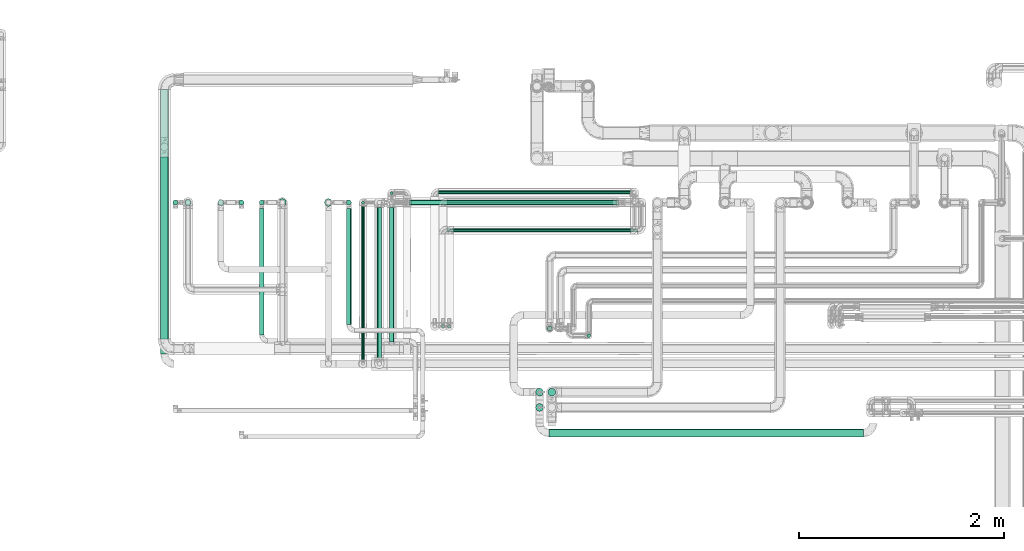
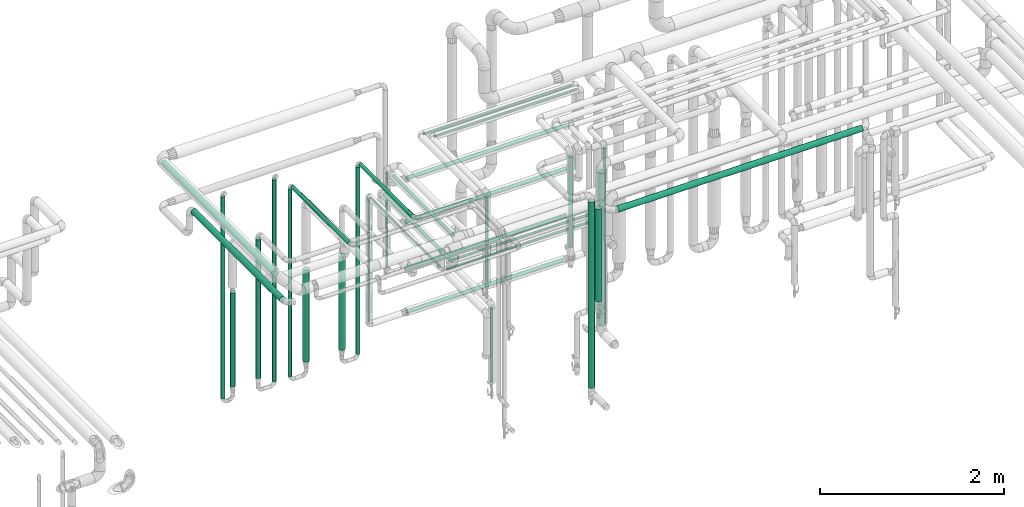
# One storey, part 541 of 827: 33 flow segments.
"""IFC2X3 building model written with IfcOpenShell, lengths in millimetres."""

from ifc_helpers import new_model, entity, si_unit, converted_unit, derived_unit, direction, frame, origin, origin_2d_with_axis, place, context, subcontext, project, spatial, circle, extrude, type_object, element, save


model = new_model("IFC2X3")

# Units and contexts
model_context = context("Model", 3, precision=0.01, world=origin(), true_north=direction((6.12303176911189e-17, 1.0)))
body_context = subcontext(model_context, "Body", "Model", "MODEL_VIEW")
ifc_project = project(units=[si_unit("LENGTHUNIT", "METRE", prefix="MILLI"), si_unit("AREAUNIT", "SQUARE_METRE"), si_unit("VOLUMEUNIT", "CUBIC_METRE"), converted_unit("PLANEANGLEUNIT", "DEGREE", entity("IfcRatioMeasure", 0.0174532925199433), si_unit("PLANEANGLEUNIT", "RADIAN"), dimensions=[0, 0, 0, 0, 0, 0, 0]), si_unit("MASSUNIT", "GRAM", prefix="KILO"), derived_unit("MASSDENSITYUNIT", [(si_unit("MASSUNIT", "GRAM", prefix="KILO"), 1), (si_unit("LENGTHUNIT", "METRE"), -3)]), derived_unit("MOMENTOFINERTIAUNIT", [(si_unit("LENGTHUNIT", "METRE"), 4)]), si_unit("TIMEUNIT", "SECOND"), si_unit("FREQUENCYUNIT", "HERTZ"), si_unit("THERMODYNAMICTEMPERATUREUNIT", "DEGREE_CELSIUS"), derived_unit("THERMALTRANSMITTANCEUNIT", [(si_unit("MASSUNIT", "GRAM", prefix="KILO"), 1), (si_unit("THERMODYNAMICTEMPERATUREUNIT", "KELVIN"), -1), (si_unit("TIMEUNIT", "SECOND"), -3)]), derived_unit("VOLUMETRICFLOWRATEUNIT", [(si_unit("LENGTHUNIT", "METRE"), 3), (si_unit("TIMEUNIT", "SECOND"), -1)]), derived_unit("MASSFLOWRATEUNIT", [(si_unit("MASSUNIT", "GRAM", prefix="KILO"), 1), (si_unit("TIMEUNIT", "SECOND"), -1)]), derived_unit("ROTATIONALFREQUENCYUNIT", [(si_unit("TIMEUNIT", "SECOND"), -1)]), si_unit("ELECTRICCURRENTUNIT", "AMPERE"), si_unit("ELECTRICVOLTAGEUNIT", "VOLT"), si_unit("POWERUNIT", "WATT"), si_unit("FORCEUNIT", "NEWTON", prefix="KILO"), si_unit("ILLUMINANCEUNIT", "LUX"), si_unit("LUMINOUSFLUXUNIT", "LUMEN"), si_unit("LUMINOUSINTENSITYUNIT", "CANDELA"), derived_unit("USERDEFINED", [(si_unit("MASSUNIT", "GRAM", prefix="KILO"), -1), (si_unit("LENGTHUNIT", "METRE"), -2), (si_unit("TIMEUNIT", "SECOND"), 3), (si_unit("LUMINOUSFLUXUNIT", "LUMEN"), 1)]), derived_unit("LINEARVELOCITYUNIT", [(si_unit("LENGTHUNIT", "METRE"), 1), (si_unit("TIMEUNIT", "SECOND"), -1)]), si_unit("PRESSUREUNIT", "PASCAL"), derived_unit("USERDEFINED", [(si_unit("LENGTHUNIT", "METRE"), -2), (si_unit("MASSUNIT", "GRAM", prefix="KILO"), 1), (si_unit("TIMEUNIT", "SECOND"), -2)]), derived_unit("LINEARFORCEUNIT", [(si_unit("MASSUNIT", "GRAM", prefix="KILO"), 1), (si_unit("LENGTHUNIT", "METRE"), 1), (si_unit("TIMEUNIT", "SECOND"), -2), (si_unit("LENGTHUNIT", "METRE"), -1)]), derived_unit("PLANARFORCEUNIT", [(si_unit("MASSUNIT", "GRAM", prefix="KILO"), 1), (si_unit("LENGTHUNIT", "METRE"), 1), (si_unit("TIMEUNIT", "SECOND"), -2), (si_unit("LENGTHUNIT", "METRE"), -2)])], contexts=[model_context])

# Site, building, storey
site_placement = place(None, origin())
site = spatial("IfcSite", under=ifc_project, at=site_placement, CompositionType="ELEMENT")
building_placement = place(site_placement, origin())
building = spatial("IfcBuilding", under=site, at=building_placement, CompositionType="ELEMENT")
storey_placement = place(building_placement, frame((0.0, 0.0, 28200.0)))
storey = spatial("IfcBuildingStorey", under=building, at=storey_placement, Name="08", CompositionType="ELEMENT", Elevation=28200.0)

# Flow segments
pipe_segment_type = type_object("IfcPipeSegmentType", PredefinedType="NOTDEFINED")
flow_segment_1_placement = place(storey_placement, frame((51929.03, 16167.38, 2910.65)))
element("IfcFlowSegment", 1, at=flow_segment_1_placement, inside=storey, type_object=pipe_segment_type, context=body_context, shape_type="SweptSolid", body=[
    extrude(circle(Radius=37.75, at=origin_2d_with_axis()), frame((39.35, 0.0, 39.35), z_axis=(0.0, 1.0, 0.0), x_axis=(1.0, 0.0, 0.0)), (0.0, 0.0, 1.0), 2437.8284365613),
])
flow_segment_2_placement = place(storey_placement, frame((51928.76, 16017.38, 2660.65)))
element("IfcFlowSegment", 2, at=flow_segment_2_placement, inside=storey, type_object=pipe_segment_type, context=body_context, shape_type="SweptSolid", body=[
    extrude(circle(Radius=37.75, at=origin_2d_with_axis()), frame((39.35, 0.0, 39.35), z_axis=(0.0, 1.0, 0.0), x_axis=(1.0, 0.0, 0.0)), (0.0, 0.0, 1.0), 1930.00000000001),
])
flow_segment_3_placement = place(storey_placement, frame((55730.84, 15206.86, 3010.65)))
element("IfcFlowSegment", 3, at=flow_segment_3_placement, inside=storey, type_object=pipe_segment_type, context=body_context, shape_type="SweptSolid", body=[
    extrude(circle(Radius=37.75, at=origin_2d_with_axis()), frame((0.0, 39.35, 39.35), z_axis=(1.0, 0.0, 0.0), x_axis=(0.0, 1.0, 0.0)), (0.0, 0.0, 1.0), 3072.07068849464),
])
flow_segment_4_placement = place(storey_placement, frame((56099.79, 16179.59, 822.74)))
element("IfcFlowSegment", 4, at=flow_segment_4_placement, inside=storey, type_object=pipe_segment_type, context=body_context, shape_type="SweptSolid", body=[
    extrude(circle(Radius=16.75, at=origin_2d_with_axis()), frame((18.35, 18.35, 0.0)), (0.0, 0.0, 1.0), 2339.25681119431),
])
flow_segment_5_placement = place(storey_placement, frame((55708.58, 16242.34, 1944.16)))
element("IfcFlowSegment", 5, at=flow_segment_5_placement, inside=storey, type_object=pipe_segment_type, context=body_context, shape_type="SweptSolid", body=[
    extrude(circle(Radius=24.0, at=origin_2d_with_axis()), frame((25.6, 25.6, 0.0)), (0.0, 0.0, 1.0), 1198.83653388558),
])
flow_segment_6_placement = place(storey_placement, frame((55596.5, 15456.86, 1725.5)))
element("IfcFlowSegment", 6, at=flow_segment_6_placement, inside=storey, type_object=pipe_segment_type, context=body_context, shape_type="SweptSolid", body=[
    extrude(circle(Radius=37.75, at=origin_2d_with_axis()), frame((39.35, 39.35, 0.0)), (0.0, 0.0, 1.0), 1229.49999999998),
])
flow_segment_7_placement = place(storey_placement, frame((55716.5, 15606.86, 1280.0)))
element("IfcFlowSegment", 7, at=flow_segment_7_placement, inside=storey, type_object=pipe_segment_type, context=body_context, shape_type="SweptSolid", body=[
    extrude(circle(Radius=37.75, at=origin_2d_with_axis()), frame((39.35, 39.35, 0.0)), (0.0, 0.0, 1.0), 2024.99999999996),
])
flow_segment_8_placement = place(storey_placement, frame((55596.5, 15606.86, 484.5)))
element("IfcFlowSegment", 8, at=flow_segment_8_placement, inside=storey, type_object=pipe_segment_type, context=body_context, shape_type="SweptSolid", body=[
    extrude(circle(Radius=37.75, at=origin_2d_with_axis()), frame((39.35, 39.35, 0.0), z_axis=(0.0, 0.0, 1.0), x_axis=(-1.0, 0.0, 0.0)), (0.0, 0.0, 1.0), 2470.49999999997),
])
flow_segment_9_placement = place(storey_placement, frame((54730.19, 17481.65, 2981.65)))
element("IfcFlowSegment", 9, at=flow_segment_9_placement, inside=storey, type_object=pipe_segment_type, context=body_context, shape_type="SweptSolid", body=[
    extrude(circle(Radius=16.75, at=origin_2d_with_axis()), frame((0.0, 18.35, 18.35), z_axis=(1.0, 0.0, 0.0), x_axis=(0.0, -1.0, 0.0)), (0.0, 0.0, 1.0), 1795.03888037783),
])
flow_segment_10_placement = place(storey_placement, frame((54650.19, 17580.47, 2981.74)))
element("IfcFlowSegment", 10, at=flow_segment_10_placement, inside=storey, type_object=pipe_segment_type, context=body_context, shape_type="SweptSolid", body=[
    extrude(circle(Radius=16.75, at=origin_2d_with_axis()), frame((0.0, 18.35, 18.35), z_axis=(1.0, 0.0, 0.0), x_axis=(0.0, -1.0, 0.0)), (0.0, 0.0, 1.0), 1875.03888037783),
])
flow_segment_11_placement = place(storey_placement, frame((54673.84, 16270.22, 1817.59)))
element("IfcFlowSegment", 11, at=flow_segment_11_placement, inside=storey, type_object=pipe_segment_type, context=body_context, shape_type="SweptSolid", body=[
    extrude(circle(Radius=16.75, at=origin_2d_with_axis()), frame((18.35, 18.35, 0.0)), (0.0, 0.0, 1.0), 1144.50000000002),
])
flow_segment_12_placement = place(storey_placement, frame((54792.23, 17210.22, 1481.65)))
element("IfcFlowSegment", 12, at=flow_segment_12_placement, inside=storey, type_object=pipe_segment_type, context=body_context, shape_type="SweptSolid", body=[
    extrude(circle(Radius=16.75, at=origin_2d_with_axis()), frame((0.0, 18.35, 18.35), z_axis=(1.0, 0.0, 0.0), x_axis=(0.0, -1.0, 0.0)), (0.0, 0.0, 1.0), 1734.00000000001),
])
flow_segment_13_placement = place(storey_placement, frame((54730.19, 17210.22, 1381.65)))
element("IfcFlowSegment", 13, at=flow_segment_13_placement, inside=storey, type_object=pipe_segment_type, context=body_context, shape_type="SweptSolid", body=[
    extrude(circle(Radius=16.75, at=origin_2d_with_axis()), frame((0.0, 18.35, 18.35), z_axis=(1.0, 0.0, 0.0), x_axis=(0.0, -1.0, 0.0)), (0.0, 0.0, 1.0), 1865.03888037782),
])
flow_segment_14_placement = place(storey_placement, frame((54735.88, 16270.22, 462.5)))
element("IfcFlowSegment", 14, at=flow_segment_14_placement, inside=storey, type_object=pipe_segment_type, context=body_context, shape_type="SweptSolid", body=[
    extrude(circle(Radius=16.75, at=origin_2d_with_axis()), frame((18.35, 18.35, 0.0)), (0.0, 0.0, 1.0), 999.50000000002),
])
flow_segment_15_placement = place(storey_placement, frame((52695.46, 17474.4, 457.0)))
element("IfcFlowSegment", 15, at=flow_segment_15_placement, inside=storey, type_object=pipe_segment_type, context=body_context, shape_type="SweptSolid", body=[
    extrude(circle(Radius=24.0, at=origin_2d_with_axis()), frame((25.6, 25.6, 0.0), z_axis=(0.0, 0.0, 1.0), x_axis=(-1.0, 0.0, 0.0)), (0.0, 0.0, 1.0), 2686.00000000001),
])
flow_segment_16_placement = place(storey_placement, frame((52893.79, 17474.4, 457.0)))
element("IfcFlowSegment", 16, at=flow_segment_16_placement, inside=storey, type_object=pipe_segment_type, context=body_context, shape_type="SweptSolid", body=[
    extrude(circle(Radius=24.0, at=origin_2d_with_axis()), frame((25.6, 25.6, 0.0), z_axis=(0.0, 0.0, 1.0), x_axis=(-1.0, 0.0, 0.0)), (0.0, 0.0, 1.0), 2486.00000000001),
])
flow_segment_17_placement = place(storey_placement, frame((52893.79, 16204.94, 2974.4)))
element("IfcFlowSegment", 17, at=flow_segment_17_placement, inside=storey, type_object=pipe_segment_type, context=body_context, shape_type="SweptSolid", body=[
    extrude(circle(Radius=24.0, at=origin_2d_with_axis()), frame((25.6, 0.0, 25.6), z_axis=(0.0, 1.0, 0.0), x_axis=(-1.0, 0.0, 0.0)), (0.0, 0.0, 1.0), 1238.06409905174),
])
flow_segment_18_placement = place(storey_placement, frame((52048.79, 17474.4, 457.0)))
element("IfcFlowSegment", 18, at=flow_segment_18_placement, inside=storey, type_object=pipe_segment_type, context=body_context, shape_type="SweptSolid", body=[
    extrude(circle(Radius=24.0, at=origin_2d_with_axis()), frame((25.6, 25.6, 0.0), z_axis=(0.0, 0.0, 1.0), x_axis=(-1.0, 0.0, 0.0)), (0.0, 0.0, 1.0), 2686.0),
])
flow_segment_19_placement = place(storey_placement, frame((53745.81, 16306.47, 2974.4)))
element("IfcFlowSegment", 19, at=flow_segment_19_placement, inside=storey, type_object=pipe_segment_type, context=body_context, shape_type="SweptSolid", body=[
    extrude(circle(Radius=24.0, at=origin_2d_with_axis()), frame((25.6, 0.0, 25.6), z_axis=(0.0, 1.0, 0.0), x_axis=(-1.0, 0.0, 0.0)), (0.0, 0.0, 1.0), 1136.52888589102),
])
flow_segment_20_placement = place(storey_placement, frame((54167.04, 16136.38, 2677.25)))
element("IfcFlowSegment", 20, at=flow_segment_20_placement, inside=storey, type_object=pipe_segment_type, context=body_context, shape_type="SweptSolid", body=[
    extrude(circle(Radius=21.15, at=origin_2d_with_axis()), frame((22.75, 0.0, 22.75), z_axis=(0.0, 1.0, 0.0), x_axis=(1.0, 0.0, 0.0)), (0.0, 0.0, 1.0), 1315.622696356),
])
flow_segment_21_placement = place(storey_placement, frame((53894.79, 15951.48, 2483.17)))
element("IfcFlowSegment", 21, at=flow_segment_21_placement, inside=storey, type_object=pipe_segment_type, context=body_context, shape_type="SweptSolid", body=[
    extrude(circle(Radius=13.4, at=origin_2d_with_axis()), frame((15.0, 0.0, 15.0), z_axis=(0.0, 1.0, 0.0), x_axis=(-1.0, 0.0, 0.0)), (0.0, 0.0, 1.0), 1519.42269635604),
])
flow_segment_22_placement = place(storey_placement, frame((53745.81, 17474.4, 457.0)))
element("IfcFlowSegment", 22, at=flow_segment_22_placement, inside=storey, type_object=pipe_segment_type, context=body_context, shape_type="SweptSolid", body=[
    extrude(circle(Radius=24.0, at=origin_2d_with_axis()), frame((25.6, 25.6, 0.0)), (0.0, 0.0, 1.0), 2486.0),
])
flow_segment_23_placement = place(storey_placement, frame((54047.04, 15970.38, 2477.25)))
element("IfcFlowSegment", 23, at=flow_segment_23_placement, inside=storey, type_object=pipe_segment_type, context=body_context, shape_type="SweptSolid", body=[
    extrude(circle(Radius=21.15, at=origin_2d_with_axis()), frame((22.75, 0.0, 22.75), z_axis=(0.0, 1.0, 0.0), x_axis=(1.0, 0.0, 0.0)), (0.0, 0.0, 1.0), 1481.62269635603),
])
flow_segment_24_placement = place(storey_placement, frame((54174.79, 17577.38, 1399.1)))
element("IfcFlowSegment", 24, at=flow_segment_24_placement, inside=storey, type_object=pipe_segment_type, context=body_context, shape_type="SweptSolid", body=[
    extrude(circle(Radius=13.4, at=origin_2d_with_axis()), frame((15.0, 15.0, 0.0)), (0.0, 0.0, 1.0), 1271.80000000001),
])
flow_segment_25_placement = place(storey_placement, frame((52166.68, 17468.4, 576.0)))
element("IfcFlowSegment", 25, at=flow_segment_25_placement, inside=storey, type_object=pipe_segment_type, context=body_context, shape_type="SweptSolid", body=[
    extrude(circle(Radius=30.0, at=origin_2d_with_axis()), frame((31.6, 31.6, 0.0), z_axis=(0.0, 0.0, 1.0), x_axis=(-1.0, 0.0, 0.0)), (0.0, 0.0, 1.0), 1246.16926665746),
])
flow_segment_26_placement = place(storey_placement, frame((52487.79, 17467.44, 576.0)))
element("IfcFlowSegment", 26, at=flow_segment_26_placement, inside=storey, type_object=pipe_segment_type, context=body_context, shape_type="SweptSolid", body=[
    extrude(circle(Radius=30.0, at=origin_2d_with_axis()), frame((31.6, 31.6, 0.0), z_axis=(0.0, 0.0, 1.0), x_axis=(-1.0, 0.0, 0.0)), (0.0, 0.0, 1.0), 1846.16926665747),
])
flow_segment_27_placement = place(storey_placement, frame((54378.79, 17474.4, 766.9)))
element("IfcFlowSegment", 27, at=flow_segment_27_placement, inside=storey, type_object=pipe_segment_type, context=body_context, shape_type="SweptSolid", body=[
    extrude(circle(Radius=24.0, at=origin_2d_with_axis()), frame((0.0, 25.6, 25.6), z_axis=(1.0, 0.0, 0.0), x_axis=(0.0, -1.0, 0.0)), (0.0, 0.0, 1.0), 1975.43821642111),
])
flow_segment_28_placement = place(storey_placement, frame((54363.79, 17474.4, 1344.4)))
element("IfcFlowSegment", 28, at=flow_segment_28_placement, inside=storey, type_object=pipe_segment_type, context=body_context, shape_type="SweptSolid", body=[
    extrude(circle(Radius=24.0, at=origin_2d_with_axis()), frame((0.0, 25.6, 25.6), z_axis=(1.0, 0.0, 0.0), x_axis=(0.0, -1.0, 0.0)), (0.0, 0.0, 1.0), 2026.43821642109),
])
flow_segment_29_placement = place(storey_placement, frame((54363.79, 17474.4, 1966.9)))
element("IfcFlowSegment", 29, at=flow_segment_29_placement, inside=storey, type_object=pipe_segment_type, context=body_context, shape_type="SweptSolid", body=[
    extrude(circle(Radius=24.0, at=origin_2d_with_axis()), frame((0.0, 25.6, 25.6), z_axis=(1.0, 0.0, 0.0), x_axis=(0.0, -1.0, 0.0)), (0.0, 0.0, 1.0), 2026.89933604333),
])
flow_segment_30_placement = place(storey_placement, frame((54378.79, 17474.4, 2541.9)))
element("IfcFlowSegment", 30, at=flow_segment_30_placement, inside=storey, type_object=pipe_segment_type, context=body_context, shape_type="SweptSolid", body=[
    extrude(circle(Radius=24.0, at=origin_2d_with_axis()), frame((0.0, 25.6, 25.6), z_axis=(1.0, 0.0, 0.0), x_axis=(0.0, 1.0, 0.0)), (0.0, 0.0, 1.0), 2029.3993360433),
])
flow_segment_31_placement = place(storey_placement, frame((53081.71, 17460.65, 589.0)))
element("IfcFlowSegment", 31, at=flow_segment_31_placement, inside=storey, type_object=pipe_segment_type, context=body_context, shape_type="SweptSolid", body=[
    extrude(circle(Radius=37.75, at=origin_2d_with_axis()), frame((39.35, 39.35, 0.0), z_axis=(0.0, 0.0, 1.0), x_axis=(-1.0, 0.0, 0.0)), (0.0, 0.0, 1.0), 1220.16926665746),
])
flow_segment_32_placement = place(storey_placement, frame((53532.06, 17460.65, 589.0)))
element("IfcFlowSegment", 32, at=flow_segment_32_placement, inside=storey, type_object=pipe_segment_type, context=body_context, shape_type="SweptSolid", body=[
    extrude(circle(Radius=37.75, at=origin_2d_with_axis()), frame((39.35, 39.35, 0.0), z_axis=(0.0, 0.0, 1.0), x_axis=(-1.0, 0.0, 0.0)), (0.0, 0.0, 1.0), 1240.16926665746),
])
flow_segment_33_placement = place(storey_placement, frame((53894.79, 17485.0, 821.6)))
element("IfcFlowSegment", 33, at=flow_segment_33_placement, inside=storey, type_object=pipe_segment_type, context=body_context, shape_type="SweptSolid", body=[
    extrude(circle(Radius=13.4, at=origin_2d_with_axis()), frame((15.0, 15.0, 0.0), z_axis=(0.0, 0.0, 1.0), x_axis=(-1.0, 0.0, 0.0)), (0.0, 0.0, 1.0), 1647.4692666575),
])

save(model, "model.ifc")
